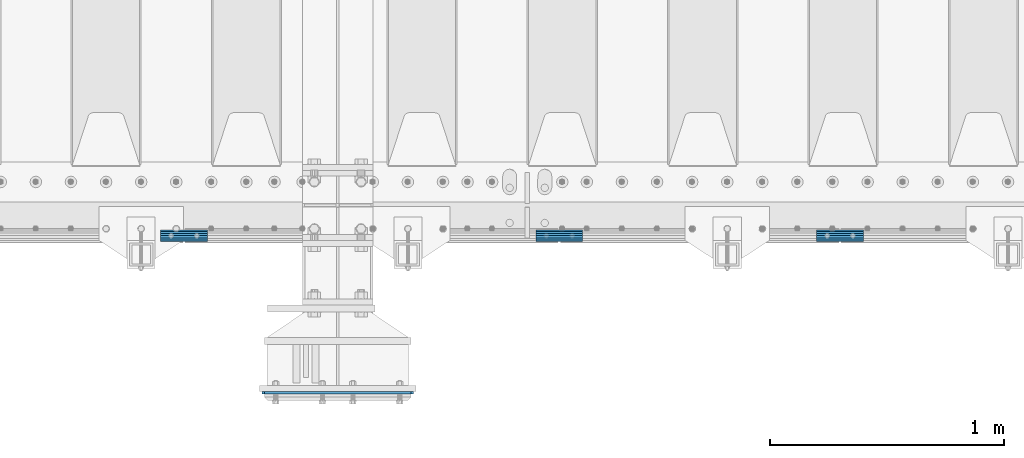
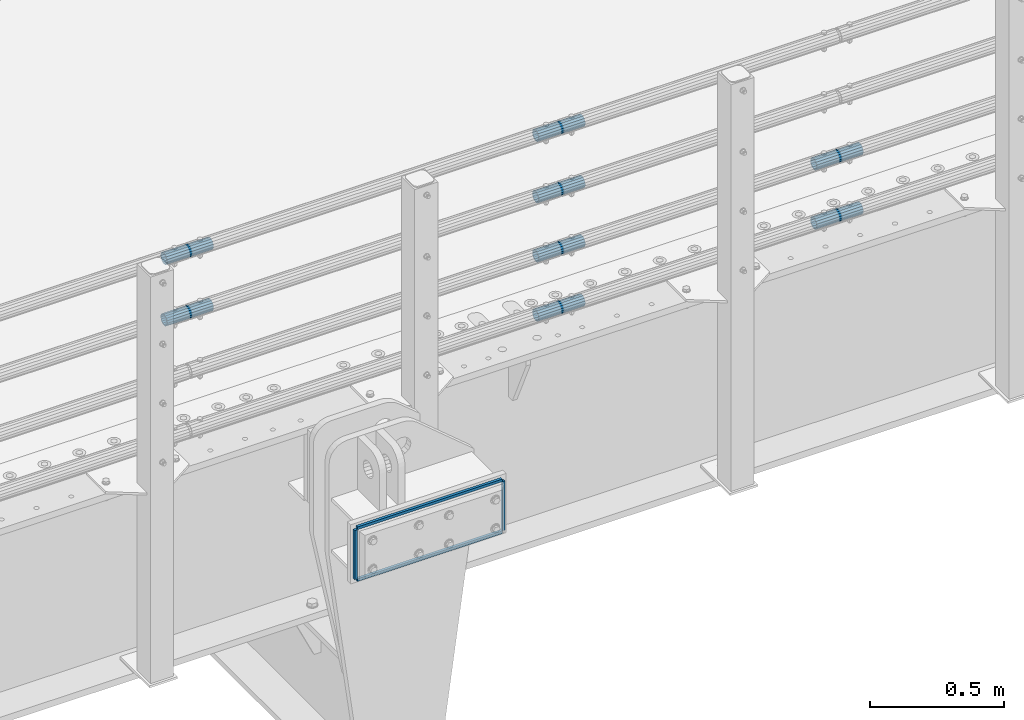
# One storey, part 136 of 240: 12 beams.
"""IFC2X3 building model written with IfcOpenShell, lengths in millimetres."""

from ifc_helpers import new_model, si_unit, frame, origin_with_axes, place, context, subcontext, project, spatial, faceted_brep, material, type_object, element, save


model = new_model("IFC2X3")

# Units and contexts
model_context = context("Model", 3, precision=1e-05, world=origin_with_axes())
body_context = subcontext(model_context, "Body", "Model", "MODEL_VIEW")
ifc_project = project(units=[si_unit("LENGTHUNIT", "METRE", prefix="MILLI"), si_unit("AREAUNIT", "SQUARE_METRE"), si_unit("VOLUMEUNIT", "CUBIC_METRE"), si_unit("MASSUNIT", "GRAM", prefix="KILO"), si_unit("TIMEUNIT", "SECOND"), si_unit("PLANEANGLEUNIT", "RADIAN"), si_unit("SOLIDANGLEUNIT", "STERADIAN"), si_unit("THERMODYNAMICTEMPERATUREUNIT", "DEGREE_CELSIUS"), si_unit("LUMINOUSINTENSITYUNIT", "LUMEN")], contexts=[model_context])

# Site, building, storey
site_placement = place(None, origin_with_axes())
site = spatial("IfcSite", under=ifc_project, at=site_placement, CompositionType="ELEMENT")
building_placement = place(site_placement, origin_with_axes())
building = spatial("IfcBuilding", under=site, at=building_placement, Name="Standard", CompositionType="ELEMENT")
storey_placement = place(building_placement, origin_with_axes())
storey = spatial("IfcBuildingStorey", under=building, at=storey_placement, Name="Undefined", CompositionType="ELEMENT", Elevation=0.0)

# Beams
ifc_material_1 = material(Name="STEEL/S355N")
beam_type_1 = type_object("IfcBeamType", PredefinedType="NOTDEFINED")
for number, where, z_axis, x_axis in (
    (1, (52521.4999999992, 23199.0000000346, -12.500018222276), (-1.0, 0.0, 0.0), (0.0, 0.0, -1.0)),
    (2, (53158.5, 23199.0000000345, -12.5000182222758), (-1.0, 0.0, 0.0), (0.0, 0.0, -1.0)),
):
    element("IfcBeam", number, at=place(storey_placement, frame(where, z_axis=z_axis, x_axis=x_axis)), inside=storey, type_object=beam_type_1, material=ifc_material_1, context=body_context, shape_type="Brep", body=[
        faceted_brep([(0.0, 6.0, -6.0), (0.0, 6.0, 6.0), (225.0, 6.0, 6.0), (225.0, 6.0, -6.0), (0.0, -6.0, 6.0), (225.0, -6.0, 6.0), (0.0, -6.0, -6.0), (225.0, -6.0, -6.0)], [[[0, 1, 2, 3]], [[1, 4, 5, 2]], [[4, 6, 7, 5]], [[6, 0, 3, 7]], [[5, 7, 3, 2]], [[6, 4, 1, 0]]]),
    ])
for number, where, z_axis, x_axis in (
    (3, (52527.5, 23199.0000000345, -6.5000182222758), (0.0, 0.0, -1.0), (1.0, 0.0, 0.0)),
    (4, (52527.5, 23199.0000000345, -243.500018222276), (0.0, 0.0, -1.0), (1.0, 0.0, 0.0)),
):
    element("IfcBeam", number, at=place(storey_placement, frame(where, z_axis=z_axis, x_axis=x_axis)), inside=storey, type_object=beam_type_1, material=ifc_material_1, context=body_context, shape_type="Brep", body=[
        faceted_brep([(0.0, 6.0, -6.0), (0.0, 6.0, 6.0), (625.0, 6.0, 6.0), (625.0, 6.0, -6.0), (0.0, -6.0, 6.0), (625.0, -6.0, 6.0), (0.0, -6.0, -6.0), (625.0, -6.0, -6.0)], [[[0, 1, 2, 3]], [[1, 4, 5, 2]], [[4, 6, 7, 5]], [[6, 0, 3, 7]], [[5, 7, 3, 2]], [[6, 4, 1, 0]]]),
    ])
ifc_material_2 = material()
beam_type_2 = type_object("IfcBeamType", PredefinedType="NOTDEFINED")
beam_1_placement = place(storey_placement, frame((53686.9975029999, 23870.1500000004, 149.849999999747), z_axis=(0.0, 0.0, 1.0), x_axis=(1.0, 0.0, 0.0)))
element("IfcBeam", 5, at=beam_1_placement, inside=storey, type_object=beam_type_2, material=ifc_material_2, context=body_context, shape_type="Brep", body=[
    faceted_brep([(0.0, -21.9000000000015, 0.0), (0.0, -20.232961761998, 8.38076716879547), (200.0, -20.232961761998, 8.38076716879547), (200.0, -21.9000000000015, 0.0), (0.0, -15.4856385079838, 15.4856385079854), (200.0, -15.4856385079838, 15.4856385079854), (0.0, -8.38076716879732, 20.2329617619972), (200.0, -8.38076716879732, 20.2329617619972), (0.0, 0.0, 21.9), (200.0, 0.0, 21.9), (0.0, 8.38076716879732, 20.2329617619972), (200.0, 8.38076716879732, 20.2329617619972), (0.0, 15.4856385079838, 15.4856385079854), (200.0, 15.4856385079838, 15.4856385079854), (0.0, 20.232961761998, 8.38076716879547), (200.0, 20.232961761998, 8.38076716879547), (0.0, 21.9000000000015, 0.0), (200.0, 21.9000000000015, 0.0), (0.0, 20.232961761998, -8.38076716879547), (200.0, 20.232961761998, -8.38076716879547), (0.0, 15.4856385079838, -15.4856385079854), (200.0, 15.4856385079838, -15.4856385079854), (0.0, 8.38076716879732, -20.2329617619972), (200.0, 8.38076716879732, -20.2329617619972), (0.0, 0.0, -21.9), (200.0, 0.0, -21.9), (0.0, -8.38076716879732, -20.2329617619972), (200.0, -8.38076716879732, -20.2329617619972), (0.0, -15.4856385079838, -15.4856385079854), (200.0, -15.4856385079838, -15.4856385079854), (0.0, -20.232961761998, -8.38076716879547), (200.0, -20.232961761998, -8.38076716879547), (0.0, -25.5, 0.0), (0.0, -23.5589280790373, -9.7584275253098), (200.0, -23.5589280790373, -9.7584275253098), (200.0, -25.5, 0.0), (0.0, -18.0312229202536, -18.031222920257), (200.0, -18.0312229202536, -18.031222920257), (0.0, -9.75842752531025, -23.5589280790378), (200.0, -9.75842752531025, -23.5589280790378), (0.0, 0.0, -25.5), (200.0, 0.0, -25.5), (0.0, 9.75842752531025, -23.5589280790378), (200.0, 9.75842752531025, -23.5589280790378), (0.0, 18.0312229202536, -18.031222920257), (200.0, 18.0312229202536, -18.031222920257), (0.0, 23.5589280790373, -9.7584275253098), (200.0, 23.5589280790373, -9.7584275253098), (0.0, 25.5, 0.0), (200.0, 25.5, 0.0), (0.0, 23.5589280790373, 9.7584275253098), (200.0, 23.5589280790373, 9.7584275253098), (0.0, 18.0312229202536, 18.031222920257), (200.0, 18.0312229202536, 18.031222920257), (0.0, 9.75842752531025, 23.5589280790378), (200.0, 9.75842752531025, 23.5589280790378), (0.0, 0.0, 25.5), (200.0, 0.0, 25.5), (0.0, -9.75842752531025, 23.5589280790378), (200.0, -9.75842752531025, 23.5589280790378), (0.0, -18.0312229202536, 18.031222920257), (200.0, -18.0312229202536, 18.031222920257), (0.0, -23.5589280790373, 9.7584275253098), (200.0, -23.5589280790373, 9.7584275253098)], [[[0, 1, 2, 3]], [[1, 4, 5, 2]], [[4, 6, 7, 5]], [[6, 8, 9, 7]], [[8, 10, 11, 9]], [[10, 12, 13, 11]], [[12, 14, 15, 13]], [[14, 16, 17, 15]], [[16, 18, 19, 17]], [[18, 20, 21, 19]], [[20, 22, 23, 21]], [[22, 24, 25, 23]], [[24, 26, 27, 25]], [[26, 28, 29, 27]], [[28, 30, 31, 29]], [[30, 0, 3, 31]], [[32, 33, 34, 35]], [[33, 36, 37, 34]], [[36, 38, 39, 37]], [[38, 40, 41, 39]], [[40, 42, 43, 41]], [[42, 44, 45, 43]], [[44, 46, 47, 45]], [[46, 48, 49, 47]], [[48, 50, 51, 49]], [[50, 52, 53, 51]], [[52, 54, 55, 53]], [[54, 56, 57, 55]], [[56, 58, 59, 57]], [[58, 60, 61, 59]], [[60, 62, 63, 61]], [[62, 32, 35, 63]], [[37, 39, 41, 43, 45, 47, 49, 51, 53, 55, 57, 59, 61, 63, 35, 34], [5, 7, 9, 11, 13, 15, 17, 19, 21, 23, 25, 27, 29, 31, 3, 2]], [[62, 60, 58, 56, 54, 52, 50, 48, 46, 44, 42, 40, 38, 36, 33, 32], [30, 28, 26, 24, 22, 20, 18, 16, 14, 12, 10, 8, 6, 4, 1, 0]]]),
])
beam_2_placement = place(storey_placement, frame((53686.9975029999, 23870.1500000004, 420.149999999747), z_axis=(0.0, 0.0, 1.0), x_axis=(1.0, 0.0, 0.0)))
element("IfcBeam", 6, at=beam_2_placement, inside=storey, type_object=beam_type_2, material=ifc_material_2, context=body_context, shape_type="Brep", body=[
    faceted_brep([(0.0, -21.9000000000015, 0.0), (0.0, -20.232961761998, 8.38076716879547), (200.0, -20.232961761998, 8.38076716879547), (200.0, -21.9000000000015, 0.0), (0.0, -15.4856385079838, 15.4856385079854), (200.0, -15.4856385079838, 15.4856385079854), (0.0, -8.38076716879732, 20.2329617619972), (200.0, -8.38076716879732, 20.2329617619972), (0.0, 0.0, 21.9), (200.0, 0.0, 21.9), (0.0, 8.38076716879732, 20.2329617619972), (200.0, 8.38076716879732, 20.2329617619972), (0.0, 15.4856385079838, 15.4856385079854), (200.0, 15.4856385079838, 15.4856385079854), (0.0, 20.232961761998, 8.38076716879547), (200.0, 20.232961761998, 8.38076716879547), (0.0, 21.9000000000015, 0.0), (200.0, 21.9000000000015, 0.0), (0.0, 20.232961761998, -8.38076716879547), (200.0, 20.232961761998, -8.38076716879547), (0.0, 15.4856385079838, -15.4856385079854), (200.0, 15.4856385079838, -15.4856385079854), (0.0, 8.38076716879732, -20.2329617619972), (200.0, 8.38076716879732, -20.2329617619972), (0.0, 0.0, -21.9), (200.0, 0.0, -21.9), (0.0, -8.38076716879732, -20.2329617619972), (200.0, -8.38076716879732, -20.2329617619972), (0.0, -15.4856385079838, -15.4856385079854), (200.0, -15.4856385079838, -15.4856385079854), (0.0, -20.232961761998, -8.38076716879547), (200.0, -20.232961761998, -8.38076716879547), (0.0, -25.5, 0.0), (0.0, -23.5589280790373, -9.7584275253098), (200.0, -23.5589280790373, -9.7584275253098), (200.0, -25.5, 0.0), (0.0, -18.0312229202536, -18.031222920257), (200.0, -18.0312229202536, -18.031222920257), (0.0, -9.75842752531025, -23.5589280790378), (200.0, -9.75842752531025, -23.5589280790378), (0.0, 0.0, -25.5), (200.0, 0.0, -25.5), (0.0, 9.75842752531025, -23.5589280790378), (200.0, 9.75842752531025, -23.5589280790378), (0.0, 18.0312229202536, -18.031222920257), (200.0, 18.0312229202536, -18.031222920257), (0.0, 23.5589280790373, -9.7584275253098), (200.0, 23.5589280790373, -9.7584275253098), (0.0, 25.5, 0.0), (200.0, 25.5, 0.0), (0.0, 23.5589280790373, 9.7584275253098), (200.0, 23.5589280790373, 9.7584275253098), (0.0, 18.0312229202536, 18.031222920257), (200.0, 18.0312229202536, 18.031222920257), (0.0, 9.75842752531025, 23.5589280790378), (200.0, 9.75842752531025, 23.5589280790378), (0.0, 0.0, 25.5), (200.0, 0.0, 25.5), (0.0, -9.75842752531025, 23.5589280790378), (200.0, -9.75842752531025, 23.5589280790378), (0.0, -18.0312229202536, 18.031222920257), (200.0, -18.0312229202536, 18.031222920257), (0.0, -23.5589280790373, 9.7584275253098), (200.0, -23.5589280790373, 9.7584275253098)], [[[0, 1, 2, 3]], [[1, 4, 5, 2]], [[4, 6, 7, 5]], [[6, 8, 9, 7]], [[8, 10, 11, 9]], [[10, 12, 13, 11]], [[12, 14, 15, 13]], [[14, 16, 17, 15]], [[16, 18, 19, 17]], [[18, 20, 21, 19]], [[20, 22, 23, 21]], [[22, 24, 25, 23]], [[24, 26, 27, 25]], [[26, 28, 29, 27]], [[28, 30, 31, 29]], [[30, 0, 3, 31]], [[32, 33, 34, 35]], [[33, 36, 37, 34]], [[36, 38, 39, 37]], [[38, 40, 41, 39]], [[40, 42, 43, 41]], [[42, 44, 45, 43]], [[44, 46, 47, 45]], [[46, 48, 49, 47]], [[48, 50, 51, 49]], [[50, 52, 53, 51]], [[52, 54, 55, 53]], [[54, 56, 57, 55]], [[56, 58, 59, 57]], [[58, 60, 61, 59]], [[60, 62, 63, 61]], [[62, 32, 35, 63]], [[37, 39, 41, 43, 45, 47, 49, 51, 53, 55, 57, 59, 61, 63, 35, 34], [5, 7, 9, 11, 13, 15, 17, 19, 21, 23, 25, 27, 29, 31, 3, 2]], [[62, 60, 58, 56, 54, 52, 50, 48, 46, 44, 42, 40, 38, 36, 33, 32], [30, 28, 26, 24, 22, 20, 18, 16, 14, 12, 10, 8, 6, 4, 1, 0]]]),
])
beam_3_placement = place(storey_placement, frame((52082.9975029999, 23870.1500000004, 969.849999999747), z_axis=(0.0, 0.0, 1.0), x_axis=(1.0, 0.0, 0.0)))
element("IfcBeam", 7, at=beam_3_placement, inside=storey, type_object=beam_type_2, material=ifc_material_2, context=body_context, shape_type="Brep", body=[
    faceted_brep([(0.0, -21.9000000000015, 0.0), (0.0, -20.232961761998, 8.38076716879547), (200.0, -20.232961761998, 8.38076716879547), (200.0, -21.9000000000015, 0.0), (0.0, -15.4856385079838, 15.4856385079854), (200.0, -15.4856385079838, 15.4856385079854), (0.0, -8.38076716879732, 20.2329617619972), (200.0, -8.38076716879732, 20.2329617619972), (0.0, 0.0, 21.9), (200.0, 0.0, 21.9), (0.0, 8.38076716879732, 20.2329617619972), (200.0, 8.38076716879732, 20.2329617619972), (0.0, 15.4856385079838, 15.4856385079854), (200.0, 15.4856385079838, 15.4856385079854), (0.0, 20.232961761998, 8.38076716879547), (200.0, 20.232961761998, 8.38076716879547), (0.0, 21.9000000000015, 0.0), (200.0, 21.9000000000015, 0.0), (0.0, 20.232961761998, -8.38076716879547), (200.0, 20.232961761998, -8.38076716879547), (0.0, 15.4856385079838, -15.4856385079854), (200.0, 15.4856385079838, -15.4856385079854), (0.0, 8.38076716879732, -20.2329617619972), (200.0, 8.38076716879732, -20.2329617619972), (0.0, 0.0, -21.9), (200.0, 0.0, -21.9), (0.0, -8.38076716879732, -20.2329617619972), (200.0, -8.38076716879732, -20.2329617619972), (0.0, -15.4856385079838, -15.4856385079854), (200.0, -15.4856385079838, -15.4856385079854), (0.0, -20.232961761998, -8.38076716879547), (200.0, -20.232961761998, -8.38076716879547), (0.0, -25.5, 0.0), (0.0, -23.5589280790373, -9.7584275253098), (200.0, -23.5589280790373, -9.7584275253098), (200.0, -25.5, 0.0), (0.0, -18.0312229202536, -18.031222920257), (200.0, -18.0312229202536, -18.031222920257), (0.0, -9.75842752531025, -23.5589280790378), (200.0, -9.75842752531025, -23.5589280790378), (0.0, 0.0, -25.5), (200.0, 0.0, -25.5), (0.0, 9.75842752531025, -23.5589280790378), (200.0, 9.75842752531025, -23.5589280790378), (0.0, 18.0312229202536, -18.031222920257), (200.0, 18.0312229202536, -18.031222920257), (0.0, 23.5589280790373, -9.7584275253098), (200.0, 23.5589280790373, -9.7584275253098), (0.0, 25.5, 0.0), (200.0, 25.5, 0.0), (0.0, 23.5589280790373, 9.7584275253098), (200.0, 23.5589280790373, 9.7584275253098), (0.0, 18.0312229202536, 18.031222920257), (200.0, 18.0312229202536, 18.031222920257), (0.0, 9.75842752531025, 23.5589280790378), (200.0, 9.75842752531025, 23.5589280790378), (0.0, 0.0, 25.5), (200.0, 0.0, 25.5), (0.0, -9.75842752531025, 23.5589280790378), (200.0, -9.75842752531025, 23.5589280790378), (0.0, -18.0312229202536, 18.031222920257), (200.0, -18.0312229202536, 18.031222920257), (0.0, -23.5589280790373, 9.7584275253098), (200.0, -23.5589280790373, 9.7584275253098)], [[[0, 1, 2, 3]], [[1, 4, 5, 2]], [[4, 6, 7, 5]], [[6, 8, 9, 7]], [[8, 10, 11, 9]], [[10, 12, 13, 11]], [[12, 14, 15, 13]], [[14, 16, 17, 15]], [[16, 18, 19, 17]], [[18, 20, 21, 19]], [[20, 22, 23, 21]], [[22, 24, 25, 23]], [[24, 26, 27, 25]], [[26, 28, 29, 27]], [[28, 30, 31, 29]], [[30, 0, 3, 31]], [[32, 33, 34, 35]], [[33, 36, 37, 34]], [[36, 38, 39, 37]], [[38, 40, 41, 39]], [[40, 42, 43, 41]], [[42, 44, 45, 43]], [[44, 46, 47, 45]], [[46, 48, 49, 47]], [[48, 50, 51, 49]], [[50, 52, 53, 51]], [[52, 54, 55, 53]], [[54, 56, 57, 55]], [[56, 58, 59, 57]], [[58, 60, 61, 59]], [[60, 62, 63, 61]], [[62, 32, 35, 63]], [[37, 39, 41, 43, 45, 47, 49, 51, 53, 55, 57, 59, 61, 63, 35, 34], [5, 7, 9, 11, 13, 15, 17, 19, 21, 23, 25, 27, 29, 31, 3, 2]], [[62, 60, 58, 56, 54, 52, 50, 48, 46, 44, 42, 40, 38, 36, 33, 32], [30, 28, 26, 24, 22, 20, 18, 16, 14, 12, 10, 8, 6, 4, 1, 0]]]),
])
beam_4_placement = place(storey_placement, frame((53686.9975029999, 23870.1500000004, 969.849999999747), z_axis=(0.0, 0.0, 1.0), x_axis=(1.0, 0.0, 0.0)))
element("IfcBeam", 8, at=beam_4_placement, inside=storey, type_object=beam_type_2, material=ifc_material_2, context=body_context, shape_type="Brep", body=[
    faceted_brep([(0.0, -21.9000000000015, 0.0), (0.0, -20.232961761998, 8.38076716879547), (200.0, -20.232961761998, 8.38076716879547), (200.0, -21.9000000000015, 0.0), (0.0, -15.4856385079838, 15.4856385079854), (200.0, -15.4856385079838, 15.4856385079854), (0.0, -8.38076716879732, 20.2329617619972), (200.0, -8.38076716879732, 20.2329617619972), (0.0, 0.0, 21.9), (200.0, 0.0, 21.9), (0.0, 8.38076716879732, 20.2329617619972), (200.0, 8.38076716879732, 20.2329617619972), (0.0, 15.4856385079838, 15.4856385079854), (200.0, 15.4856385079838, 15.4856385079854), (0.0, 20.232961761998, 8.38076716879547), (200.0, 20.232961761998, 8.38076716879547), (0.0, 21.9000000000015, 0.0), (200.0, 21.9000000000015, 0.0), (0.0, 20.232961761998, -8.38076716879547), (200.0, 20.232961761998, -8.38076716879547), (0.0, 15.4856385079838, -15.4856385079854), (200.0, 15.4856385079838, -15.4856385079854), (0.0, 8.38076716879732, -20.2329617619972), (200.0, 8.38076716879732, -20.2329617619972), (0.0, 0.0, -21.9), (200.0, 0.0, -21.9), (0.0, -8.38076716879732, -20.2329617619972), (200.0, -8.38076716879732, -20.2329617619972), (0.0, -15.4856385079838, -15.4856385079854), (200.0, -15.4856385079838, -15.4856385079854), (0.0, -20.232961761998, -8.38076716879547), (200.0, -20.232961761998, -8.38076716879547), (0.0, -25.5, 0.0), (0.0, -23.5589280790373, -9.7584275253098), (200.0, -23.5589280790373, -9.7584275253098), (200.0, -25.5, 0.0), (0.0, -18.0312229202536, -18.031222920257), (200.0, -18.0312229202536, -18.031222920257), (0.0, -9.75842752531025, -23.5589280790378), (200.0, -9.75842752531025, -23.5589280790378), (0.0, 0.0, -25.5), (200.0, 0.0, -25.5), (0.0, 9.75842752531025, -23.5589280790378), (200.0, 9.75842752531025, -23.5589280790378), (0.0, 18.0312229202536, -18.031222920257), (200.0, 18.0312229202536, -18.031222920257), (0.0, 23.5589280790373, -9.7584275253098), (200.0, 23.5589280790373, -9.7584275253098), (0.0, 25.5, 0.0), (200.0, 25.5, 0.0), (0.0, 23.5589280790373, 9.7584275253098), (200.0, 23.5589280790373, 9.7584275253098), (0.0, 18.0312229202536, 18.031222920257), (200.0, 18.0312229202536, 18.031222920257), (0.0, 9.75842752531025, 23.5589280790378), (200.0, 9.75842752531025, 23.5589280790378), (0.0, 0.0, 25.5), (200.0, 0.0, 25.5), (0.0, -9.75842752531025, 23.5589280790378), (200.0, -9.75842752531025, 23.5589280790378), (0.0, -18.0312229202536, 18.031222920257), (200.0, -18.0312229202536, 18.031222920257), (0.0, -23.5589280790373, 9.7584275253098), (200.0, -23.5589280790373, 9.7584275253098)], [[[0, 1, 2, 3]], [[1, 4, 5, 2]], [[4, 6, 7, 5]], [[6, 8, 9, 7]], [[8, 10, 11, 9]], [[10, 12, 13, 11]], [[12, 14, 15, 13]], [[14, 16, 17, 15]], [[16, 18, 19, 17]], [[18, 20, 21, 19]], [[20, 22, 23, 21]], [[22, 24, 25, 23]], [[24, 26, 27, 25]], [[26, 28, 29, 27]], [[28, 30, 31, 29]], [[30, 0, 3, 31]], [[32, 33, 34, 35]], [[33, 36, 37, 34]], [[36, 38, 39, 37]], [[38, 40, 41, 39]], [[40, 42, 43, 41]], [[42, 44, 45, 43]], [[44, 46, 47, 45]], [[46, 48, 49, 47]], [[48, 50, 51, 49]], [[50, 52, 53, 51]], [[52, 54, 55, 53]], [[54, 56, 57, 55]], [[56, 58, 59, 57]], [[58, 60, 61, 59]], [[60, 62, 63, 61]], [[62, 32, 35, 63]], [[37, 39, 41, 43, 45, 47, 49, 51, 53, 55, 57, 59, 61, 63, 35, 34], [5, 7, 9, 11, 13, 15, 17, 19, 21, 23, 25, 27, 29, 31, 3, 2]], [[62, 60, 58, 56, 54, 52, 50, 48, 46, 44, 42, 40, 38, 36, 33, 32], [30, 28, 26, 24, 22, 20, 18, 16, 14, 12, 10, 8, 6, 4, 1, 0]]]),
])
beam_5_placement = place(storey_placement, frame((54886.9975029999, 23870.1500000004, 419.849999999747), z_axis=(0.0, 0.0, 1.0), x_axis=(1.0, 0.0, 0.0)))
element("IfcBeam", 9, at=beam_5_placement, inside=storey, type_object=beam_type_2, material=ifc_material_2, context=body_context, shape_type="Brep", body=[
    faceted_brep([(0.0, -21.9000000000015, 0.0), (0.0, -20.232961761998, 8.38076716879547), (200.0, -20.232961761998, 8.38076716879547), (200.0, -21.9000000000015, 0.0), (0.0, -15.4856385079838, 15.4856385079854), (200.0, -15.4856385079838, 15.4856385079854), (0.0, -8.38076716879732, 20.2329617619972), (200.0, -8.38076716879732, 20.2329617619972), (0.0, 0.0, 21.9), (200.0, 0.0, 21.9), (0.0, 8.38076716879732, 20.2329617619972), (200.0, 8.38076716879732, 20.2329617619972), (0.0, 15.4856385079838, 15.4856385079854), (200.0, 15.4856385079838, 15.4856385079854), (0.0, 20.232961761998, 8.38076716879547), (200.0, 20.232961761998, 8.38076716879547), (0.0, 21.9000000000015, 0.0), (200.0, 21.9000000000015, 0.0), (0.0, 20.232961761998, -8.38076716879547), (200.0, 20.232961761998, -8.38076716879547), (0.0, 15.4856385079838, -15.4856385079854), (200.0, 15.4856385079838, -15.4856385079854), (0.0, 8.38076716879732, -20.2329617619972), (200.0, 8.38076716879732, -20.2329617619972), (0.0, 0.0, -21.9), (200.0, 0.0, -21.9), (0.0, -8.38076716879732, -20.2329617619972), (200.0, -8.38076716879732, -20.2329617619972), (0.0, -15.4856385079838, -15.4856385079854), (200.0, -15.4856385079838, -15.4856385079854), (0.0, -20.232961761998, -8.38076716879547), (200.0, -20.232961761998, -8.38076716879547), (0.0, -25.5, 0.0), (0.0, -23.5589280790373, -9.7584275253098), (200.0, -23.5589280790373, -9.7584275253098), (200.0, -25.5, 0.0), (0.0, -18.0312229202536, -18.031222920257), (200.0, -18.0312229202536, -18.031222920257), (0.0, -9.75842752531025, -23.5589280790378), (200.0, -9.75842752531025, -23.5589280790378), (0.0, 0.0, -25.5), (200.0, 0.0, -25.5), (0.0, 9.75842752531025, -23.5589280790378), (200.0, 9.75842752531025, -23.5589280790378), (0.0, 18.0312229202536, -18.031222920257), (200.0, 18.0312229202536, -18.031222920257), (0.0, 23.5589280790373, -9.7584275253098), (200.0, 23.5589280790373, -9.7584275253098), (0.0, 25.5, 0.0), (200.0, 25.5, 0.0), (0.0, 23.5589280790373, 9.7584275253098), (200.0, 23.5589280790373, 9.7584275253098), (0.0, 18.0312229202536, 18.031222920257), (200.0, 18.0312229202536, 18.031222920257), (0.0, 9.75842752531025, 23.5589280790378), (200.0, 9.75842752531025, 23.5589280790378), (0.0, 0.0, 25.5), (200.0, 0.0, 25.5), (0.0, -9.75842752531025, 23.5589280790378), (200.0, -9.75842752531025, 23.5589280790378), (0.0, -18.0312229202536, 18.031222920257), (200.0, -18.0312229202536, 18.031222920257), (0.0, -23.5589280790373, 9.7584275253098), (200.0, -23.5589280790373, 9.7584275253098)], [[[0, 1, 2, 3]], [[1, 4, 5, 2]], [[4, 6, 7, 5]], [[6, 8, 9, 7]], [[8, 10, 11, 9]], [[10, 12, 13, 11]], [[12, 14, 15, 13]], [[14, 16, 17, 15]], [[16, 18, 19, 17]], [[18, 20, 21, 19]], [[20, 22, 23, 21]], [[22, 24, 25, 23]], [[24, 26, 27, 25]], [[26, 28, 29, 27]], [[28, 30, 31, 29]], [[30, 0, 3, 31]], [[32, 33, 34, 35]], [[33, 36, 37, 34]], [[36, 38, 39, 37]], [[38, 40, 41, 39]], [[40, 42, 43, 41]], [[42, 44, 45, 43]], [[44, 46, 47, 45]], [[46, 48, 49, 47]], [[48, 50, 51, 49]], [[50, 52, 53, 51]], [[52, 54, 55, 53]], [[54, 56, 57, 55]], [[56, 58, 59, 57]], [[58, 60, 61, 59]], [[60, 62, 63, 61]], [[62, 32, 35, 63]], [[37, 39, 41, 43, 45, 47, 49, 51, 53, 55, 57, 59, 61, 63, 35, 34], [5, 7, 9, 11, 13, 15, 17, 19, 21, 23, 25, 27, 29, 31, 3, 2]], [[62, 60, 58, 56, 54, 52, 50, 48, 46, 44, 42, 40, 38, 36, 33, 32], [30, 28, 26, 24, 22, 20, 18, 16, 14, 12, 10, 8, 6, 4, 1, 0]]]),
])
beam_6_placement = place(storey_placement, frame((54886.9975029999, 23870.1500000004, 149.849999999747), z_axis=(0.0, 0.0, 1.0), x_axis=(1.0, 0.0, 0.0)))
element("IfcBeam", 10, at=beam_6_placement, inside=storey, type_object=beam_type_2, material=ifc_material_2, context=body_context, shape_type="Brep", body=[
    faceted_brep([(0.0, -21.9000000000015, 0.0), (0.0, -20.232961761998, 8.38076716879547), (200.0, -20.232961761998, 8.38076716879547), (200.0, -21.9000000000015, 0.0), (0.0, -15.4856385079838, 15.4856385079854), (200.0, -15.4856385079838, 15.4856385079854), (0.0, -8.38076716879732, 20.2329617619972), (200.0, -8.38076716879732, 20.2329617619972), (0.0, 0.0, 21.9), (200.0, 0.0, 21.9), (0.0, 8.38076716879732, 20.2329617619972), (200.0, 8.38076716879732, 20.2329617619972), (0.0, 15.4856385079838, 15.4856385079854), (200.0, 15.4856385079838, 15.4856385079854), (0.0, 20.232961761998, 8.38076716879547), (200.0, 20.232961761998, 8.38076716879547), (0.0, 21.9000000000015, 0.0), (200.0, 21.9000000000015, 0.0), (0.0, 20.232961761998, -8.38076716879547), (200.0, 20.232961761998, -8.38076716879547), (0.0, 15.4856385079838, -15.4856385079854), (200.0, 15.4856385079838, -15.4856385079854), (0.0, 8.38076716879732, -20.2329617619972), (200.0, 8.38076716879732, -20.2329617619972), (0.0, 0.0, -21.9), (200.0, 0.0, -21.9), (0.0, -8.38076716879732, -20.2329617619972), (200.0, -8.38076716879732, -20.2329617619972), (0.0, -15.4856385079838, -15.4856385079854), (200.0, -15.4856385079838, -15.4856385079854), (0.0, -20.232961761998, -8.38076716879547), (200.0, -20.232961761998, -8.38076716879547), (0.0, -25.5, 0.0), (0.0, -23.5589280790373, -9.7584275253098), (200.0, -23.5589280790373, -9.7584275253098), (200.0, -25.5, 0.0), (0.0, -18.0312229202536, -18.031222920257), (200.0, -18.0312229202536, -18.031222920257), (0.0, -9.75842752531025, -23.5589280790378), (200.0, -9.75842752531025, -23.5589280790378), (0.0, 0.0, -25.5), (200.0, 0.0, -25.5), (0.0, 9.75842752531025, -23.5589280790378), (200.0, 9.75842752531025, -23.5589280790378), (0.0, 18.0312229202536, -18.031222920257), (200.0, 18.0312229202536, -18.031222920257), (0.0, 23.5589280790373, -9.7584275253098), (200.0, 23.5589280790373, -9.7584275253098), (0.0, 25.5, 0.0), (200.0, 25.5, 0.0), (0.0, 23.5589280790373, 9.7584275253098), (200.0, 23.5589280790373, 9.7584275253098), (0.0, 18.0312229202536, 18.031222920257), (200.0, 18.0312229202536, 18.031222920257), (0.0, 9.75842752531025, 23.5589280790378), (200.0, 9.75842752531025, 23.5589280790378), (0.0, 0.0, 25.5), (200.0, 0.0, 25.5), (0.0, -9.75842752531025, 23.5589280790378), (200.0, -9.75842752531025, 23.5589280790378), (0.0, -18.0312229202536, 18.031222920257), (200.0, -18.0312229202536, 18.031222920257), (0.0, -23.5589280790373, 9.7584275253098), (200.0, -23.5589280790373, 9.7584275253098)], [[[0, 1, 2, 3]], [[1, 4, 5, 2]], [[4, 6, 7, 5]], [[6, 8, 9, 7]], [[8, 10, 11, 9]], [[10, 12, 13, 11]], [[12, 14, 15, 13]], [[14, 16, 17, 15]], [[16, 18, 19, 17]], [[18, 20, 21, 19]], [[20, 22, 23, 21]], [[22, 24, 25, 23]], [[24, 26, 27, 25]], [[26, 28, 29, 27]], [[28, 30, 31, 29]], [[30, 0, 3, 31]], [[32, 33, 34, 35]], [[33, 36, 37, 34]], [[36, 38, 39, 37]], [[38, 40, 41, 39]], [[40, 42, 43, 41]], [[42, 44, 45, 43]], [[44, 46, 47, 45]], [[46, 48, 49, 47]], [[48, 50, 51, 49]], [[50, 52, 53, 51]], [[52, 54, 55, 53]], [[54, 56, 57, 55]], [[56, 58, 59, 57]], [[58, 60, 61, 59]], [[60, 62, 63, 61]], [[62, 32, 35, 63]], [[37, 39, 41, 43, 45, 47, 49, 51, 53, 55, 57, 59, 61, 63, 35, 34], [5, 7, 9, 11, 13, 15, 17, 19, 21, 23, 25, 27, 29, 31, 3, 2]], [[62, 60, 58, 56, 54, 52, 50, 48, 46, 44, 42, 40, 38, 36, 33, 32], [30, 28, 26, 24, 22, 20, 18, 16, 14, 12, 10, 8, 6, 4, 1, 0]]]),
])
beam_7_placement = place(storey_placement, frame((52082.9975029999, 23870.1500000004, 689.849999999747), z_axis=(0.0, 0.0, 1.0), x_axis=(1.0, 0.0, 0.0)))
element("IfcBeam", 11, at=beam_7_placement, inside=storey, type_object=beam_type_2, material=ifc_material_2, context=body_context, shape_type="Brep", body=[
    faceted_brep([(0.0, -21.9000000000015, 0.0), (0.0, -20.232961761998, 8.38076716879547), (200.0, -20.232961761998, 8.38076716879547), (200.0, -21.9000000000015, 0.0), (0.0, -15.4856385079838, 15.4856385079854), (200.0, -15.4856385079838, 15.4856385079854), (0.0, -8.38076716879732, 20.2329617619972), (200.0, -8.38076716879732, 20.2329617619972), (0.0, 0.0, 21.9), (200.0, 0.0, 21.9), (0.0, 8.38076716879732, 20.2329617619972), (200.0, 8.38076716879732, 20.2329617619972), (0.0, 15.4856385079838, 15.4856385079854), (200.0, 15.4856385079838, 15.4856385079854), (0.0, 20.232961761998, 8.38076716879547), (200.0, 20.232961761998, 8.38076716879547), (0.0, 21.9000000000015, 0.0), (200.0, 21.9000000000015, 0.0), (0.0, 20.232961761998, -8.38076716879547), (200.0, 20.232961761998, -8.38076716879547), (0.0, 15.4856385079838, -15.4856385079854), (200.0, 15.4856385079838, -15.4856385079854), (0.0, 8.38076716879732, -20.2329617619972), (200.0, 8.38076716879732, -20.2329617619972), (0.0, 0.0, -21.9), (200.0, 0.0, -21.9), (0.0, -8.38076716879732, -20.2329617619972), (200.0, -8.38076716879732, -20.2329617619972), (0.0, -15.4856385079838, -15.4856385079854), (200.0, -15.4856385079838, -15.4856385079854), (0.0, -20.232961761998, -8.38076716879547), (200.0, -20.232961761998, -8.38076716879547), (0.0, -25.5, 0.0), (0.0, -23.5589280790373, -9.7584275253098), (200.0, -23.5589280790373, -9.7584275253098), (200.0, -25.5, 0.0), (0.0, -18.0312229202536, -18.031222920257), (200.0, -18.0312229202536, -18.031222920257), (0.0, -9.75842752531025, -23.5589280790378), (200.0, -9.75842752531025, -23.5589280790378), (0.0, 0.0, -25.5), (200.0, 0.0, -25.5), (0.0, 9.75842752531025, -23.5589280790378), (200.0, 9.75842752531025, -23.5589280790378), (0.0, 18.0312229202536, -18.031222920257), (200.0, 18.0312229202536, -18.031222920257), (0.0, 23.5589280790373, -9.7584275253098), (200.0, 23.5589280790373, -9.7584275253098), (0.0, 25.5, 0.0), (200.0, 25.5, 0.0), (0.0, 23.5589280790373, 9.7584275253098), (200.0, 23.5589280790373, 9.7584275253098), (0.0, 18.0312229202536, 18.031222920257), (200.0, 18.0312229202536, 18.031222920257), (0.0, 9.75842752531025, 23.5589280790378), (200.0, 9.75842752531025, 23.5589280790378), (0.0, 0.0, 25.5), (200.0, 0.0, 25.5), (0.0, -9.75842752531025, 23.5589280790378), (200.0, -9.75842752531025, 23.5589280790378), (0.0, -18.0312229202536, 18.031222920257), (200.0, -18.0312229202536, 18.031222920257), (0.0, -23.5589280790373, 9.7584275253098), (200.0, -23.5589280790373, 9.7584275253098)], [[[0, 1, 2, 3]], [[1, 4, 5, 2]], [[4, 6, 7, 5]], [[6, 8, 9, 7]], [[8, 10, 11, 9]], [[10, 12, 13, 11]], [[12, 14, 15, 13]], [[14, 16, 17, 15]], [[16, 18, 19, 17]], [[18, 20, 21, 19]], [[20, 22, 23, 21]], [[22, 24, 25, 23]], [[24, 26, 27, 25]], [[26, 28, 29, 27]], [[28, 30, 31, 29]], [[30, 0, 3, 31]], [[32, 33, 34, 35]], [[33, 36, 37, 34]], [[36, 38, 39, 37]], [[38, 40, 41, 39]], [[40, 42, 43, 41]], [[42, 44, 45, 43]], [[44, 46, 47, 45]], [[46, 48, 49, 47]], [[48, 50, 51, 49]], [[50, 52, 53, 51]], [[52, 54, 55, 53]], [[54, 56, 57, 55]], [[56, 58, 59, 57]], [[58, 60, 61, 59]], [[60, 62, 63, 61]], [[62, 32, 35, 63]], [[37, 39, 41, 43, 45, 47, 49, 51, 53, 55, 57, 59, 61, 63, 35, 34], [5, 7, 9, 11, 13, 15, 17, 19, 21, 23, 25, 27, 29, 31, 3, 2]], [[62, 60, 58, 56, 54, 52, 50, 48, 46, 44, 42, 40, 38, 36, 33, 32], [30, 28, 26, 24, 22, 20, 18, 16, 14, 12, 10, 8, 6, 4, 1, 0]]]),
])
beam_8_placement = place(storey_placement, frame((53686.9975029999, 23870.1500000004, 689.849999999747), z_axis=(0.0, 0.0, 1.0), x_axis=(1.0, 0.0, 0.0)))
element("IfcBeam", 12, at=beam_8_placement, inside=storey, type_object=beam_type_2, material=ifc_material_2, context=body_context, shape_type="Brep", body=[
    faceted_brep([(0.0, -21.9000000000015, 0.0), (0.0, -20.232961761998, 8.38076716879547), (200.0, -20.232961761998, 8.38076716879547), (200.0, -21.9000000000015, 0.0), (0.0, -15.4856385079838, 15.4856385079854), (200.0, -15.4856385079838, 15.4856385079854), (0.0, -8.38076716879732, 20.2329617619972), (200.0, -8.38076716879732, 20.2329617619972), (0.0, 0.0, 21.9), (200.0, 0.0, 21.9), (0.0, 8.38076716879732, 20.2329617619972), (200.0, 8.38076716879732, 20.2329617619972), (0.0, 15.4856385079838, 15.4856385079854), (200.0, 15.4856385079838, 15.4856385079854), (0.0, 20.232961761998, 8.38076716879547), (200.0, 20.232961761998, 8.38076716879547), (0.0, 21.9000000000015, 0.0), (200.0, 21.9000000000015, 0.0), (0.0, 20.232961761998, -8.38076716879547), (200.0, 20.232961761998, -8.38076716879547), (0.0, 15.4856385079838, -15.4856385079854), (200.0, 15.4856385079838, -15.4856385079854), (0.0, 8.38076716879732, -20.2329617619972), (200.0, 8.38076716879732, -20.2329617619972), (0.0, 0.0, -21.9), (200.0, 0.0, -21.9), (0.0, -8.38076716879732, -20.2329617619972), (200.0, -8.38076716879732, -20.2329617619972), (0.0, -15.4856385079838, -15.4856385079854), (200.0, -15.4856385079838, -15.4856385079854), (0.0, -20.232961761998, -8.38076716879547), (200.0, -20.232961761998, -8.38076716879547), (0.0, -25.5, 0.0), (0.0, -23.5589280790373, -9.7584275253098), (200.0, -23.5589280790373, -9.7584275253098), (200.0, -25.5, 0.0), (0.0, -18.0312229202536, -18.031222920257), (200.0, -18.0312229202536, -18.031222920257), (0.0, -9.75842752531025, -23.5589280790378), (200.0, -9.75842752531025, -23.5589280790378), (0.0, 0.0, -25.5), (200.0, 0.0, -25.5), (0.0, 9.75842752531025, -23.5589280790378), (200.0, 9.75842752531025, -23.5589280790378), (0.0, 18.0312229202536, -18.031222920257), (200.0, 18.0312229202536, -18.031222920257), (0.0, 23.5589280790373, -9.7584275253098), (200.0, 23.5589280790373, -9.7584275253098), (0.0, 25.5, 0.0), (200.0, 25.5, 0.0), (0.0, 23.5589280790373, 9.7584275253098), (200.0, 23.5589280790373, 9.7584275253098), (0.0, 18.0312229202536, 18.031222920257), (200.0, 18.0312229202536, 18.031222920257), (0.0, 9.75842752531025, 23.5589280790378), (200.0, 9.75842752531025, 23.5589280790378), (0.0, 0.0, 25.5), (200.0, 0.0, 25.5), (0.0, -9.75842752531025, 23.5589280790378), (200.0, -9.75842752531025, 23.5589280790378), (0.0, -18.0312229202536, 18.031222920257), (200.0, -18.0312229202536, 18.031222920257), (0.0, -23.5589280790373, 9.7584275253098), (200.0, -23.5589280790373, 9.7584275253098)], [[[0, 1, 2, 3]], [[1, 4, 5, 2]], [[4, 6, 7, 5]], [[6, 8, 9, 7]], [[8, 10, 11, 9]], [[10, 12, 13, 11]], [[12, 14, 15, 13]], [[14, 16, 17, 15]], [[16, 18, 19, 17]], [[18, 20, 21, 19]], [[20, 22, 23, 21]], [[22, 24, 25, 23]], [[24, 26, 27, 25]], [[26, 28, 29, 27]], [[28, 30, 31, 29]], [[30, 0, 3, 31]], [[32, 33, 34, 35]], [[33, 36, 37, 34]], [[36, 38, 39, 37]], [[38, 40, 41, 39]], [[40, 42, 43, 41]], [[42, 44, 45, 43]], [[44, 46, 47, 45]], [[46, 48, 49, 47]], [[48, 50, 51, 49]], [[50, 52, 53, 51]], [[52, 54, 55, 53]], [[54, 56, 57, 55]], [[56, 58, 59, 57]], [[58, 60, 61, 59]], [[60, 62, 63, 61]], [[62, 32, 35, 63]], [[37, 39, 41, 43, 45, 47, 49, 51, 53, 55, 57, 59, 61, 63, 35, 34], [5, 7, 9, 11, 13, 15, 17, 19, 21, 23, 25, 27, 29, 31, 3, 2]], [[62, 60, 58, 56, 54, 52, 50, 48, 46, 44, 42, 40, 38, 36, 33, 32], [30, 28, 26, 24, 22, 20, 18, 16, 14, 12, 10, 8, 6, 4, 1, 0]]]),
])

save(model, "model.ifc")
